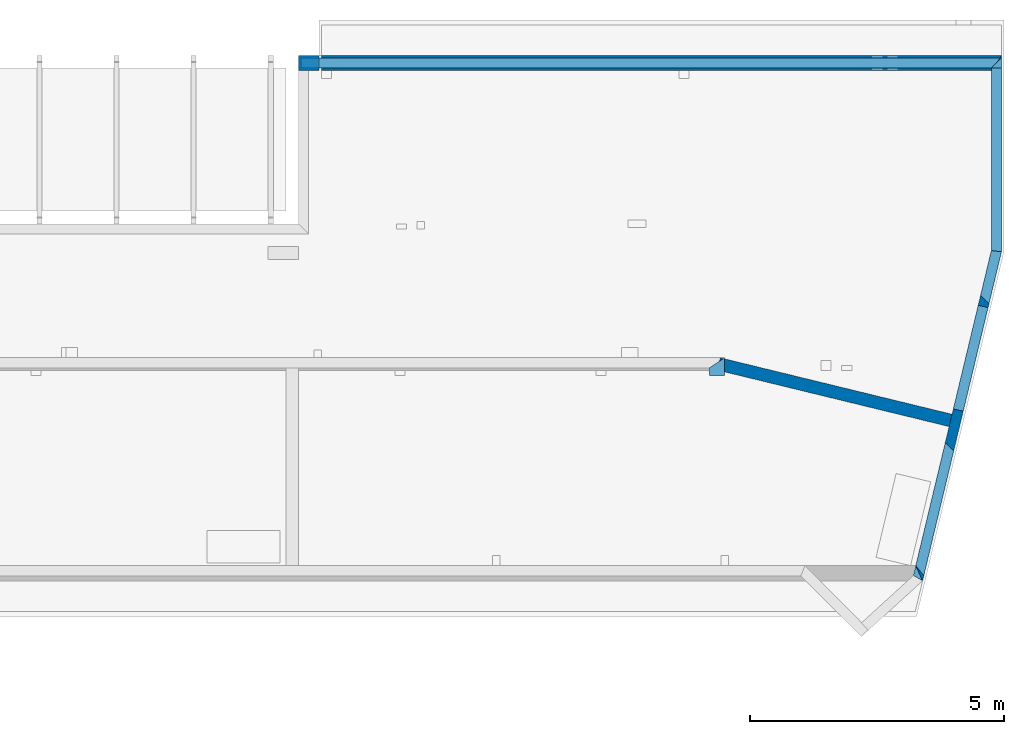
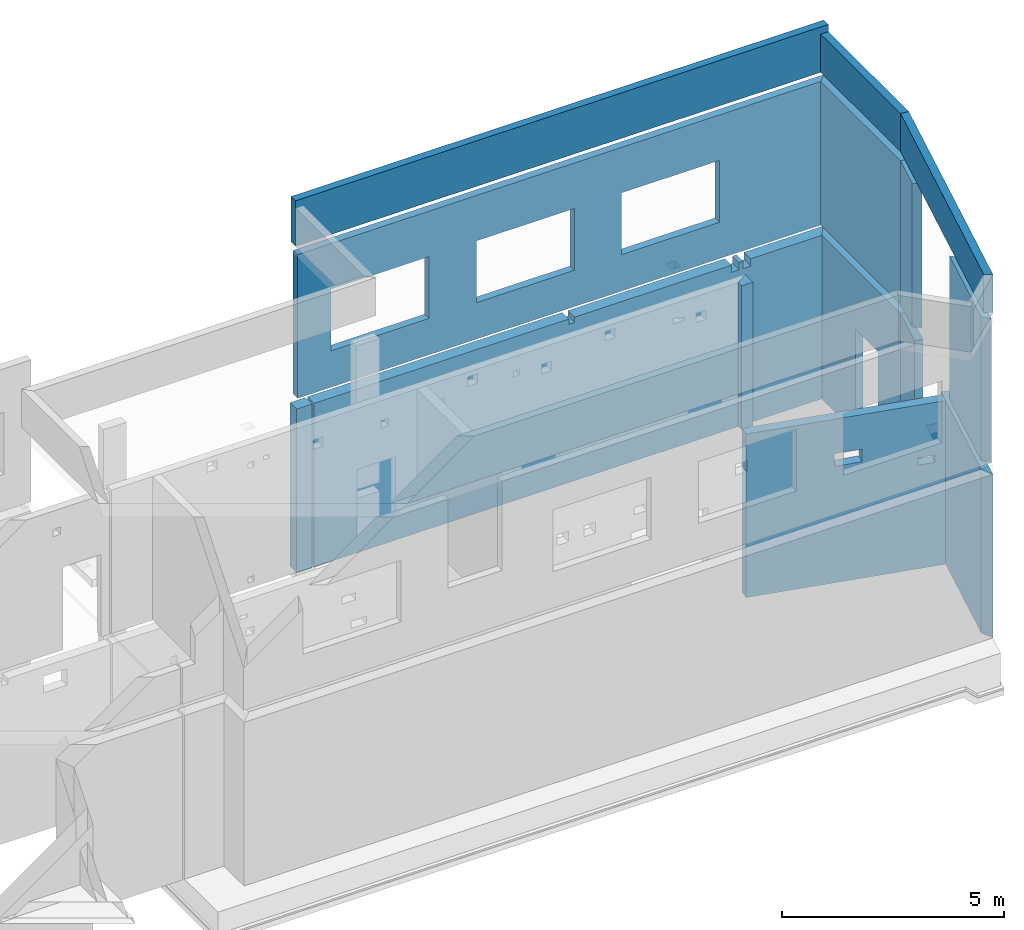
# One storey, part 4 of 7: 12 walls, 14 openings.
"""IFC2X3 building model written with IfcOpenShell, lengths in millimetres."""

from ifc_helpers import new_model, entity, si_unit, converted_unit, derived_unit, money_unit, direction, frame, frame_2d, origin_with_axes, place, context, subcontext, project, spatial, polyline, rectangle, outline, extrude, faceted_brep, material, layer, layer_set, layer_usage, type_object, element, save


model = new_model("IFC2X3")

# Units and contexts
model_context = context("Model", 3, precision=1e-05, world=origin_with_axes(), true_north=direction((0.0, 1.0)))
body_context = subcontext(model_context, "Body", "Model", "MODEL_VIEW", scale=1.0)
ifc_project = project(units=[si_unit("LENGTHUNIT", "METRE", prefix="MILLI"), si_unit("AREAUNIT", "SQUARE_METRE"), si_unit("VOLUMEUNIT", "CUBIC_METRE"), si_unit("ABSORBEDDOSEUNIT", "GRAY"), si_unit("AMOUNTOFSUBSTANCEUNIT", "MOLE"), si_unit("DOSEEQUIVALENTUNIT", "SIEVERT"), si_unit("ELECTRICCAPACITANCEUNIT", "FARAD"), si_unit("ELECTRICCHARGEUNIT", "COULOMB"), si_unit("ELECTRICCONDUCTANCEUNIT", "SIEMENS"), si_unit("ELECTRICCURRENTUNIT", "AMPERE"), si_unit("ELECTRICRESISTANCEUNIT", "OHM"), si_unit("ELECTRICVOLTAGEUNIT", "VOLT"), si_unit("ENERGYUNIT", "JOULE"), si_unit("FORCEUNIT", "NEWTON"), si_unit("FREQUENCYUNIT", "HERTZ"), si_unit("ILLUMINANCEUNIT", "LUX"), si_unit("INDUCTANCEUNIT", "HENRY"), si_unit("LUMINOUSFLUXUNIT", "LUMEN"), si_unit("LUMINOUSINTENSITYUNIT", "CANDELA"), si_unit("MAGNETICFLUXDENSITYUNIT", "TESLA"), si_unit("MAGNETICFLUXUNIT", "WEBER"), si_unit("MASSUNIT", "GRAM"), converted_unit("PLANEANGLEUNIT", "degree", entity("IfcReal", 0.0174532925199433), si_unit("PLANEANGLEUNIT", "RADIAN"), dimensions=[0, 0, 0, 0, 0, 0, 0]), si_unit("POWERUNIT", "WATT"), si_unit("PRESSUREUNIT", "PASCAL"), si_unit("RADIOACTIVITYUNIT", "BECQUEREL"), si_unit("SOLIDANGLEUNIT", "STERADIAN"), si_unit("THERMODYNAMICTEMPERATUREUNIT", "KELVIN"), si_unit("TIMEUNIT", "SECOND"), derived_unit("ACCELERATIONUNIT", [(si_unit("LENGTHUNIT", "METRE", prefix="MILLI"), 1), (si_unit("TIMEUNIT", "SECOND"), -2)]), derived_unit("ANGULARVELOCITYUNIT", [(converted_unit("PLANEANGLEUNIT", "degree", entity("IfcReal", 0.0174532925199433), si_unit("PLANEANGLEUNIT", "RADIAN"), dimensions=[0, 0, 0, 0, 0, 0, 0]), 1), (si_unit("TIMEUNIT", "SECOND"), -1)]), derived_unit("CURVATUREUNIT", [(converted_unit("PLANEANGLEUNIT", "degree", entity("IfcReal", 0.0174532925199433), si_unit("PLANEANGLEUNIT", "RADIAN"), dimensions=[0, 0, 0, 0, 0, 0, 0]), 1), (si_unit("LENGTHUNIT", "METRE", prefix="MILLI"), -1)]), derived_unit("DYNAMICVISCOSITYUNIT", [(si_unit("PRESSUREUNIT", "PASCAL"), 1), (si_unit("TIMEUNIT", "SECOND"), 1)]), derived_unit("HEATFLUXDENSITYUNIT", [(si_unit("POWERUNIT", "WATT"), 1), (si_unit("LENGTHUNIT", "METRE", prefix="MILLI"), -2)]), derived_unit("HEATINGVALUEUNIT", [(si_unit("ENERGYUNIT", "JOULE"), 1), (si_unit("MASSUNIT", "GRAM"), -1)]), derived_unit("INTEGERCOUNTRATEUNIT", [(si_unit("TIMEUNIT", "SECOND"), -1)]), derived_unit("IONCONCENTRATIONUNIT", [(si_unit("MASSUNIT", "GRAM"), 1), (si_unit("VOLUMEUNIT", "CUBIC_METRE"), -1)]), derived_unit("ISOTHERMALMOISTURECAPACITYUNIT", [(si_unit("VOLUMEUNIT", "CUBIC_METRE"), 1), (si_unit("MASSUNIT", "GRAM"), -1)]), derived_unit("KINEMATICVISCOSITYUNIT", [(si_unit("AREAUNIT", "SQUARE_METRE"), 1), (si_unit("TIMEUNIT", "SECOND"), -1)]), derived_unit("LINEARFORCEUNIT", [(si_unit("FORCEUNIT", "NEWTON"), 1), (si_unit("LENGTHUNIT", "METRE", prefix="MILLI"), -1)]), derived_unit("LINEARMOMENTUNIT", [(si_unit("FORCEUNIT", "NEWTON"), 1), (si_unit("LENGTHUNIT", "METRE", prefix="MILLI"), -1)]), derived_unit("LINEARSTIFFNESSUNIT", [(si_unit("FORCEUNIT", "NEWTON"), 1), (si_unit("LENGTHUNIT", "METRE", prefix="MILLI"), -1)]), derived_unit("LINEARVELOCITYUNIT", [(si_unit("LENGTHUNIT", "METRE", prefix="MILLI"), 1), (si_unit("TIMEUNIT", "SECOND"), -1)]), derived_unit("LUMINOUSINTENSITYDISTRIBUTIONUNIT", [(si_unit("LUMINOUSINTENSITYUNIT", "CANDELA"), 1), (si_unit("LUMINOUSFLUXUNIT", "LUMEN"), -1)]), derived_unit("MASSDENSITYUNIT", [(si_unit("MASSUNIT", "GRAM"), 1), (si_unit("VOLUMEUNIT", "CUBIC_METRE"), -1)]), derived_unit("MASSFLOWRATEUNIT", [(si_unit("MASSUNIT", "GRAM"), 1), (si_unit("TIMEUNIT", "SECOND"), -1)]), derived_unit("MASSPERLENGTHUNIT", [(si_unit("MASSUNIT", "GRAM"), 1), (si_unit("LENGTHUNIT", "METRE", prefix="MILLI"), -1)]), derived_unit("MODULUSOFELASTICITYUNIT", [(si_unit("FORCEUNIT", "NEWTON"), 1), (si_unit("AREAUNIT", "SQUARE_METRE"), -1)]), derived_unit("MODULUSOFLINEARSUBGRADEREACTIONUNIT", [(si_unit("FORCEUNIT", "NEWTON"), 1), (si_unit("LENGTHUNIT", "METRE", prefix="MILLI"), -2)]), derived_unit("MODULUSOFROTATIONALSUBGRADEREACTIONUNIT", [(si_unit("FORCEUNIT", "NEWTON"), 1), (si_unit("LENGTHUNIT", "METRE", prefix="MILLI"), 1)]), derived_unit("MODULUSOFSUBGRADEREACTIONUNIT", [(si_unit("FORCEUNIT", "NEWTON"), 1), (si_unit("VOLUMEUNIT", "CUBIC_METRE"), -1)]), derived_unit("MOISTUREDIFFUSIVITYUNIT", [(si_unit("VOLUMEUNIT", "CUBIC_METRE"), 1), (si_unit("TIMEUNIT", "SECOND"), -1)]), derived_unit("MOLECULARWEIGHTUNIT", [(si_unit("MASSUNIT", "GRAM"), 1), (si_unit("AMOUNTOFSUBSTANCEUNIT", "MOLE"), -1)]), derived_unit("PLANARFORCEUNIT", [(si_unit("FORCEUNIT", "NEWTON"), 1), (si_unit("LENGTHUNIT", "METRE", prefix="MILLI"), -2)]), derived_unit("ROTATIONALFREQUENCYUNIT", [(si_unit("TIMEUNIT", "SECOND"), -1)]), derived_unit("ROTATIONALMASSUNIT", [(si_unit("MASSUNIT", "GRAM"), 1), (si_unit("LENGTHUNIT", "METRE", prefix="MILLI"), 2)]), derived_unit("ROTATIONALSTIFFNESSUNIT", [(si_unit("FORCEUNIT", "NEWTON"), 1), (si_unit("LENGTHUNIT", "METRE", prefix="MILLI"), 1), (converted_unit("PLANEANGLEUNIT", "degree", entity("IfcReal", 0.0174532925199433), si_unit("PLANEANGLEUNIT", "RADIAN"), dimensions=[0, 0, 0, 0, 0, 0, 0]), -1)]), derived_unit("SECTIONAREAINTEGRALUNIT", [(si_unit("LENGTHUNIT", "METRE", prefix="MILLI"), 5)]), derived_unit("SECTIONMODULUSUNIT", [(si_unit("LENGTHUNIT", "METRE", prefix="MILLI"), 3)]), derived_unit("SHEARMODULUSUNIT", [(si_unit("FORCEUNIT", "NEWTON"), 1), (si_unit("AREAUNIT", "SQUARE_METRE"), -1)]), derived_unit("SOUNDPOWERUNIT", [(si_unit("ENERGYUNIT", "JOULE"), 1), (si_unit("TIMEUNIT", "SECOND"), -1)]), derived_unit("SPECIFICHEATCAPACITYUNIT", [(si_unit("FORCEUNIT", "NEWTON"), 1), (si_unit("MASSUNIT", "GRAM"), -1), (si_unit("THERMODYNAMICTEMPERATUREUNIT", "KELVIN"), -1)]), derived_unit("TEMPERATUREGRADIENTUNIT", [(si_unit("THERMODYNAMICTEMPERATUREUNIT", "KELVIN"), 1), (si_unit("LENGTHUNIT", "METRE", prefix="MILLI"), -1)]), derived_unit("THERMALADMITTANCEUNIT", [(si_unit("POWERUNIT", "WATT"), 1), (si_unit("AREAUNIT", "SQUARE_METRE"), -1), (si_unit("THERMODYNAMICTEMPERATUREUNIT", "KELVIN"), -1)]), derived_unit("THERMALCONDUCTANCEUNIT", [(si_unit("POWERUNIT", "WATT"), 1), (si_unit("LENGTHUNIT", "METRE", prefix="MILLI"), -1), (si_unit("THERMODYNAMICTEMPERATUREUNIT", "KELVIN"), -1)]), derived_unit("THERMALEXPANSIONCOEFFICIENTUNIT", [(si_unit("THERMODYNAMICTEMPERATUREUNIT", "KELVIN"), -1)]), derived_unit("THERMALRESISTANCEUNIT", [(si_unit("AREAUNIT", "SQUARE_METRE"), 1), (si_unit("POWERUNIT", "WATT"), -1)]), derived_unit("THERMALTRANSMITTANCEUNIT", [(si_unit("POWERUNIT", "WATT"), 1), (si_unit("AREAUNIT", "SQUARE_METRE"), -1), (si_unit("THERMODYNAMICTEMPERATUREUNIT", "KELVIN"), -1)]), derived_unit("TORQUEUNIT", [(si_unit("FORCEUNIT", "NEWTON"), 1), (si_unit("LENGTHUNIT", "METRE", prefix="MILLI"), 1)]), derived_unit("VAPORPERMEABILITYUNIT", [(si_unit("MASSUNIT", "GRAM"), 1), (si_unit("TIMEUNIT", "SECOND"), -1)]), derived_unit("VOLUMETRICFLOWRATEUNIT", [(si_unit("VOLUMEUNIT", "CUBIC_METRE"), 1), (si_unit("TIMEUNIT", "SECOND"), -1)]), derived_unit("WARPINGCONSTANTUNIT", [(si_unit("LENGTHUNIT", "METRE", prefix="MILLI"), 6)]), derived_unit("WARPINGMOMENTUNIT", [(si_unit("FORCEUNIT", "NEWTON"), 1), (si_unit("LENGTHUNIT", "METRE", prefix="MILLI"), 2)]), money_unit("USD")], contexts=[model_context])

# Site, building, storey
site_placement = place(None, origin_with_axes())
site = spatial("IfcSite", under=ifc_project, at=site_placement, CompositionType="ELEMENT")
building_placement = place(site_placement, origin_with_axes())
building = spatial("IfcBuilding", under=site, at=building_placement, Name="1", CompositionType="ELEMENT")
storey_placement = place(building_placement, frame((0.0, 0.0, -4900.0), z_axis=(0.0, 0.0, 1.0), x_axis=(1.0, 0.0, 0.0)))
storey = spatial("IfcBuildingStorey", under=building, at=storey_placement, CompositionType="ELEMENT", Elevation=-4900.0)

# Wall, opening
ifc_material = material()
ifc_layer_1 = layer(ifc_material, 200.0, ventilated=False)
ifc_layer_set_1 = layer_set([ifc_layer_1])
ifc_layer_usage_1 = layer_usage(ifc_layer_set_1, "AXIS2", "POSITIVE", 0.0)
wall_type = type_object("IfcWallType", PredefinedType="NOTDEFINED")
wall_1_placement = place(storey_placement, frame((28458.864598, -300.0, 0.0), z_axis=(0.0, 0.0, 1.0), x_axis=(0.23316545, 0.97243708, 0.0)))
wall_1 = element("IfcWallStandardCase", 1, at=wall_1_placement, inside=storey, type_object=wall_type, material=ifc_layer_usage_1, context=body_context, shape_type="SweptSolid", body=[
    extrude(outline(polyline([(6650.311284, 200.0), (260.548385, 200.0), (0.0, 0.0), (6673.953655, 0.0), (6650.311284, 200.0)])), origin_with_axes(), (0.0, 0.0, 1.0), 4500.0),
])
opening_1_placement = place(wall_1_placement, frame((3440.392719, 0.0, 550.0), z_axis=(0.0, 0.0, 1.0), x_axis=(1.0, 0.0, 0.0)))
element("IfcOpeningElement", 2, at=opening_1_placement, cuts=wall_1, ObjectType="Opening", context=body_context, shape_type="SweptSolid", body=[
    extrude(rectangle(XDim=3950.0, YDim=2100.0, at=frame_2d((-1050.0, 1975.0), x_axis=(0.0, -1.0))), frame((0.0, 0.0, 0.0), z_axis=(0.0, 1.0, 0.0), x_axis=(-1.0, 0.0, 0.0)), (0.0, 0.0, 1.0), 200.0),
])

wall_2_placement = place(storey_placement, frame((30015.0, 6190.0, 0.0), z_axis=(0.0, 0.0, 1.0), x_axis=(0.0, 1.0, 0.0)))
wall_2 = element("IfcWallStandardCase", 3, at=wall_2_placement, inside=storey, type_object=wall_type, material=ifc_layer_usage_1, context=body_context, shape_type="SweptSolid", body=[
    extrude(outline(polyline([(3570.0, 200.0), (23.642371, 200.0), (0.0, 0.0), (3870.0, 0.0), (3570.0, 200.0)])), origin_with_axes(), (0.0, 0.0, 1.0), 4500.0),
])
opening_2_placement = place(wall_2_placement, frame((1030.0, 0.0, 550.0), z_axis=(0.0, 0.0, 1.0), x_axis=(1.0, 0.0, 0.0)))
element("IfcOpeningElement", 4, at=opening_2_placement, cuts=wall_2, ObjectType="Opening", context=body_context, shape_type="SweptSolid", body=[
    extrude(rectangle(XDim=2280.0, YDim=1020.0, at=frame_2d((-510.0, 1140.0), x_axis=(0.0, -1.0))), frame((0.0, 0.0, 0.0), z_axis=(0.0, 1.0, 0.0), x_axis=(-1.0, 0.0, 0.0)), (0.0, 0.0, 1.0), 200.0),
])

# Wall
ifc_layer_2 = layer(ifc_material, 300.0, ventilated=False)
ifc_layer_set_2 = layer_set([ifc_layer_2])
ifc_layer_usage_2 = layer_usage(ifc_layer_set_2, "AXIS2", "POSITIVE", 0.0)
wall_3_placement = place(storey_placement, frame((16555.0, 10060.0, 0.0), z_axis=(0.0, 0.0, 1.0), x_axis=(-1.0, 0.0, 0.0)))
element("IfcWallStandardCase", 5, at=wall_3_placement, inside=storey, type_object=wall_type, material=ifc_layer_usage_2, context=body_context, shape_type="SweptSolid", body=[
    extrude(rectangle(XDim=400.0, YDim=300.0, at=frame_2d((200.0, 150.0), x_axis=(1.0, 0.0))), origin_with_axes(), (0.0, 0.0, 1.0), 4500.0),
])

# Wall, openings
wall_4_placement = place(storey_placement, frame((30015.0, 10060.0, 0.0), z_axis=(0.0, 0.0, 1.0), x_axis=(-1.0, 0.0, 0.0)))
wall_4 = element("IfcWallStandardCase", 6, at=wall_4_placement, inside=storey, type_object=wall_type, material=ifc_layer_usage_2, context=body_context, shape_type="SweptSolid", body=[
    extrude(outline(polyline([(200.0, 300.0), (0.0, 0.0), (13410.0, 0.0), (13410.0, 300.0), (200.0, 300.0)])), origin_with_axes(), (0.0, 0.0, 1.0), 4500.0),
])
opening_3_placement = place(wall_4_placement, frame((6630.0, 0.0, 4350.0), z_axis=(0.0, 0.0, 1.0), x_axis=(1.0, 0.0, 0.0)))
element("IfcOpeningElement", 7, at=opening_3_placement, cuts=wall_4, ObjectType="Opening", context=body_context, shape_type="SweptSolid", body=[
    extrude(rectangle(XDim=150.0, YDim=150.0, at=frame_2d((-75.0, 75.0), x_axis=(0.0, -1.0))), frame((0.0, 0.0, 0.0), z_axis=(0.0, 1.0, 0.0), x_axis=(-1.0, 0.0, 0.0)), (0.0, 0.0, 1.0), 300.0),
])
opening_4_placement = place(wall_4_placement, frame((2350.0, 0.0, 4300.0), z_axis=(0.0, 0.0, 1.0), x_axis=(1.0, 0.0, 0.0)))
element("IfcOpeningElement", 8, at=opening_4_placement, cuts=wall_4, ObjectType="Opening", context=body_context, shape_type="SweptSolid", body=[
    extrude(rectangle(XDim=200.0, YDim=200.0, at=frame_2d((-100.0, 100.0), x_axis=(0.0, -1.0))), frame((0.0, 0.0, 0.0), z_axis=(0.0, 1.0, 0.0), x_axis=(-1.0, 0.0, 0.0)), (0.0, 0.0, 1.0), 300.0),
])
opening_5_placement = place(wall_4_placement, frame((2050.0, 0.0, 4300.0), z_axis=(0.0, 0.0, 1.0), x_axis=(1.0, 0.0, 0.0)))
element("IfcOpeningElement", 9, at=opening_5_placement, cuts=wall_4, ObjectType="Opening", context=body_context, shape_type="SweptSolid", body=[
    extrude(rectangle(XDim=200.0, YDim=200.0, at=frame_2d((-100.0, 100.0), x_axis=(0.0, -1.0))), frame((0.0, 0.0, 0.0), z_axis=(0.0, 1.0, 0.0), x_axis=(-1.0, 0.0, 0.0)), (0.0, 0.0, 1.0), 300.0),
])

ifc_layer_3 = layer(ifc_material, 250.0, ventilated=False)
ifc_layer_set_3 = layer_set([ifc_layer_3])
ifc_layer_usage_3 = layer_usage(ifc_layer_set_3, "AXIS2", "POSITIVE", 0.0)
wall_5_placement = place(storey_placement, frame((24434.990959, 3850.0, 0.0), z_axis=(0.0, 0.0, 1.0), x_axis=(0.97159196, -0.23666233, 0.0)))
wall_5 = element("IfcWallStandardCase", 10, at=wall_5_placement, inside=storey, type_object=wall_type, material=ifc_layer_usage_3, context=body_context, shape_type="SweptSolid", body=[
    extrude(outline(polyline([(4679.731439, 250.0), (-30.009041, 250.0), (0.0, 0.0), (4680.630832, 0.0), (4679.731439, 250.0)])), origin_with_axes(), (0.0, 0.0, 1.0), 4500.0),
])
opening_6_placement = place(wall_5_placement, frame((-20.009041, 0.0, 3465.0), z_axis=(0.0, 0.0, 1.0), x_axis=(1.0, 0.0, 0.0)))
element("IfcOpeningElement", 11, at=opening_6_placement, cuts=wall_5, ObjectType="Recess", context=body_context, shape_type="Brep", body=[
    faceted_brep([(20.009041, 0.0, 0.0), (40.603118, 0.0, 0.0), (40.603118, 0.0, 300.0), (20.009041, 0.0, 300.0), (0.0, 166.691772, 0.0), (0.0, 166.691772, 300.0)], [[[0, 1, 2, 3]], [[4, 0, 3, 5]], [[4, 1, 0]], [[5, 2, 1, 4]], [[3, 2, 5]]]),
])
opening_7_placement = place(wall_5_placement, frame((2070.613942, 0.0, 3200.0), z_axis=(0.0, 0.0, 1.0), x_axis=(1.0, 0.0, 0.0)))
element("IfcOpeningElement", 12, at=opening_7_placement, cuts=wall_5, ObjectType="Opening", context=body_context, shape_type="SweptSolid", body=[
    extrude(rectangle(XDim=350.0, YDim=650.0, at=frame_2d((-325.0, 175.0), x_axis=(0.0, -1.0))), frame((0.0, 0.0, 0.0), z_axis=(0.0, 1.0, 0.0), x_axis=(-1.0, 0.0, 0.0)), (0.0, 0.0, 1.0), 250.0),
])
opening_8_placement = place(wall_5_placement, frame((4030.626626, 0.0, 2850.0), z_axis=(0.0, 0.0, 1.0), x_axis=(1.0, 0.0, 0.0)))
element("IfcOpeningElement", 13, at=opening_8_placement, cuts=wall_5, ObjectType="Opening", context=body_context, shape_type="SweptSolid", body=[
    extrude(rectangle(XDim=200.0, YDim=400.0, at=frame_2d((-200.0, 100.0), x_axis=(0.0, -1.0))), frame((0.0, 0.0, 0.0), z_axis=(0.0, 1.0, 0.0), x_axis=(-1.0, 0.0, 0.0)), (0.0, 0.0, 1.0), 250.0),
])

wall_6_placement = place(storey_placement, frame((30015.0, 10010.0, 4750.0), z_axis=(0.0, 0.0, 1.0), x_axis=(-1.0, 0.0, 0.0)))
wall_6 = element("IfcWallStandardCase", 14, at=wall_6_placement, inside=storey, type_object=wall_type, material=ifc_layer_usage_1, context=body_context, shape_type="SweptSolid", body=[
    extrude(outline(polyline([(200.0, 200.0), (0.0, 0.0), (13810.0, 0.0), (13810.0, 200.0), (200.0, 200.0)])), origin_with_axes(), (0.0, 0.0, 1.0), 3950.0),
])
opening_9_placement = place(wall_6_placement, frame((10390.0, 0.0, 1000.0), z_axis=(0.0, 0.0, 1.0), x_axis=(1.0, 0.0, 0.0)))
element("IfcOpeningElement", 15, at=opening_9_placement, cuts=wall_6, ObjectType="Opening", context=body_context, shape_type="SweptSolid", body=[
    extrude(rectangle(XDim=1700.0, YDim=2550.0, at=frame_2d((-1275.0, 850.0), x_axis=(0.0, -1.0))), frame((0.0, 0.0, 0.0), z_axis=(0.0, 1.0, 0.0), x_axis=(-1.0, 0.0, 0.0)), (0.0, 0.0, 1.0), 200.0),
])
opening_10_placement = place(wall_6_placement, frame((6610.0, 0.0, 1000.0), z_axis=(0.0, 0.0, 1.0), x_axis=(1.0, 0.0, 0.0)))
element("IfcOpeningElement", 16, at=opening_10_placement, cuts=wall_6, ObjectType="Opening", context=body_context, shape_type="SweptSolid", body=[
    extrude(rectangle(XDim=1700.0, YDim=2550.0, at=frame_2d((-1275.0, 850.0), x_axis=(0.0, -1.0))), frame((0.0, 0.0, 0.0), z_axis=(0.0, 1.0, 0.0), x_axis=(-1.0, 0.0, 0.0)), (0.0, 0.0, 1.0), 200.0),
])
opening_11_placement = place(wall_6_placement, frame((2830.0, 0.0, 1000.0), z_axis=(0.0, 0.0, 1.0), x_axis=(1.0, 0.0, 0.0)))
element("IfcOpeningElement", 17, at=opening_11_placement, cuts=wall_6, ObjectType="Opening", context=body_context, shape_type="SweptSolid", body=[
    extrude(rectangle(XDim=1700.0, YDim=2550.0, at=frame_2d((-1275.0, 850.0), x_axis=(0.0, -1.0))), frame((0.0, 0.0, 0.0), z_axis=(0.0, 1.0, 0.0), x_axis=(-1.0, 0.0, 0.0)), (0.0, 0.0, 1.0), 200.0),
])

# Wall
wall_7_placement = place(storey_placement, frame((30015.0, 10010.0, 4750.0), z_axis=(0.0, 0.0, 1.0), x_axis=(0.0, -1.0, 0.0)))
element("IfcWallStandardCase", 18, at=wall_7_placement, inside=storey, type_object=wall_type, material=ifc_layer_usage_1, context=body_context, shape_type="SweptSolid", body=[
    extrude(outline(polyline([(3820.0, 0.0), (0.0, 0.0), (200.0, -200.0), (3796.357629, -200.0), (3820.0, 0.0)])), origin_with_axes(), (0.0, 0.0, 1.0), 3950.0),
])

# Wall, openings
wall_8_placement = place(storey_placement, frame((30015.0, 6190.0, 4750.0), z_axis=(0.0, 0.0, 1.0), x_axis=(-0.23316545, -0.97243708, 0.0)))
wall_8 = element("IfcWallStandardCase", 19, at=wall_8_placement, inside=storey, type_object=wall_type, material=ifc_layer_usage_1, context=body_context, shape_type="SweptSolid", body=[
    extrude(outline(polyline([(6571.119238, 0.0), (0.0, 0.0), (23.642371, -200.0), (6413.40527, -200.0), (6571.119238, 0.0)])), origin_with_axes(), (0.0, 0.0, 1.0), 3950.0),
])
opening_12_placement = place(wall_8_placement, frame((3765.999315, -200.0, 0.0), z_axis=(0.0, 0.0, 1.0), x_axis=(1.0, 0.0, 0.0)))
element("IfcOpeningElement", 20, at=opening_12_placement, cuts=wall_8, ObjectType="Opening", context=body_context, shape_type="Brep", body=[
    faceted_brep([(125.0, 200.0, 3950.0), (0.0, 0.0, 3950.0), (147.405955, 0.0, 3950.0), (272.405955, 200.0, 3950.0), (0.0, 0.0, 0.0), (147.405955, 0.0, 0.0), (125.0, 200.0, 0.0), (272.405955, 200.0, 0.0)], [[[0, 1, 2, 3]], [[1, 4, 5, 2]], [[6, 0, 3, 7]], [[4, 6, 7, 5]], [[5, 7, 3, 2]], [[1, 0, 6, 4]]]),
])
opening_13_placement = place(wall_8_placement, frame((933.380757, -200.0, 0.0), z_axis=(0.0, 0.0, 1.0), x_axis=(1.0, 0.0, 0.0)))
element("IfcOpeningElement", 21, at=opening_13_placement, cuts=wall_8, ObjectType="Opening", context=body_context, shape_type="Brep", body=[
    faceted_brep([(125.0, 200.0, 3950.0), (0.0, 0.0, 3950.0), (147.405955, 0.0, 3950.0), (272.405955, 200.0, 3950.0), (0.0, 0.0, 0.0), (147.405955, 0.0, 0.0), (125.0, 200.0, 0.0), (272.405955, 200.0, 0.0)], [[[0, 1, 2, 3]], [[1, 4, 5, 2]], [[6, 0, 3, 7]], [[4, 6, 7, 5]], [[5, 7, 3, 2]], [[1, 0, 6, 4]]]),
])
opening_14_placement = place(wall_8_placement, frame((1058.40527, -200.0, 0.0), z_axis=(0.0, 0.0, 1.0), x_axis=(1.0, 0.0, 0.0)))
element("IfcOpeningElement", 22, at=opening_14_placement, cuts=wall_8, ObjectType="Opening", context=body_context, shape_type="SweptSolid", body=[
    extrude(rectangle(XDim=3950.0, YDim=2855.0, at=frame_2d((-1427.5, 1975.0), x_axis=(0.0, -1.0))), frame((0.0, 0.0, 0.0), z_axis=(0.0, 1.0, 0.0), x_axis=(-1.0, 0.0, 0.0)), (0.0, 0.0, 1.0), 200.0),
])

# Walls
wall_9_placement = place(storey_placement, frame((24555.0, 3750.0, 4750.0), z_axis=(0.0, 0.0, 1.0), x_axis=(0.0, 1.0, 0.0)))
element("IfcWallStandardCase", 23, at=wall_9_placement, inside=storey, type_object=wall_type, material=ifc_layer_usage_2, context=body_context, shape_type="SweptSolid", body=[
    extrude(outline(polyline([(150.0, 300.0), (0.0, 300.0), (0.0, 0.0), (350.0, 0.0), (150.0, 300.0)])), origin_with_axes(), (0.0, 0.0, 1.0), 3950.0),
])
wall_10_placement = place(storey_placement, frame((16155.0, 10010.0, 8950.0), z_axis=(0.0, 0.0, 1.0), x_axis=(1.0, 0.0, 0.0)))
element("IfcWallStandardCase", 24, at=wall_10_placement, inside=storey, type_object=wall_type, material=ifc_layer_usage_1, context=body_context, shape_type="SweptSolid", body=[
    extrude(rectangle(XDim=13860.0, YDim=200.0, at=frame_2d((6930.0, -100.0), x_axis=(1.0, 0.0))), origin_with_axes(), (0.0, 0.0, 1.0), 1250.0),
])
wall_11_placement = place(storey_placement, frame((28458.864598, -300.0, 8950.0), z_axis=(0.0, 0.0, 1.0), x_axis=(0.23316545, 0.97243708, 0.0)))
element("IfcWallStandardCase", 25, at=wall_11_placement, inside=storey, type_object=wall_type, material=ifc_layer_usage_1, context=body_context, shape_type="SweptSolid", body=[
    extrude(outline(polyline([(6650.311284, 200.0), (61.418751, 200.0), (0.0, 0.0), (6673.953655, 0.0), (6650.311284, 200.0)])), origin_with_axes(), (0.0, 0.0, 1.0), 1050.0),
])
wall_12_placement = place(storey_placement, frame((30015.0, 6190.0, 8950.0), z_axis=(0.0, 0.0, 1.0), x_axis=(0.0, 1.0, 0.0)))
element("IfcWallStandardCase", 26, at=wall_12_placement, inside=storey, type_object=wall_type, material=ifc_layer_usage_1, context=body_context, shape_type="SweptSolid", body=[
    extrude(outline(polyline([(23.642371, 200.0), (0.0, 0.0), (3620.0, 0.0), (3620.0, 200.0), (23.642371, 200.0)])), origin_with_axes(), (0.0, 0.0, 1.0), 1050.0),
])

save(model, "model.ifc")
